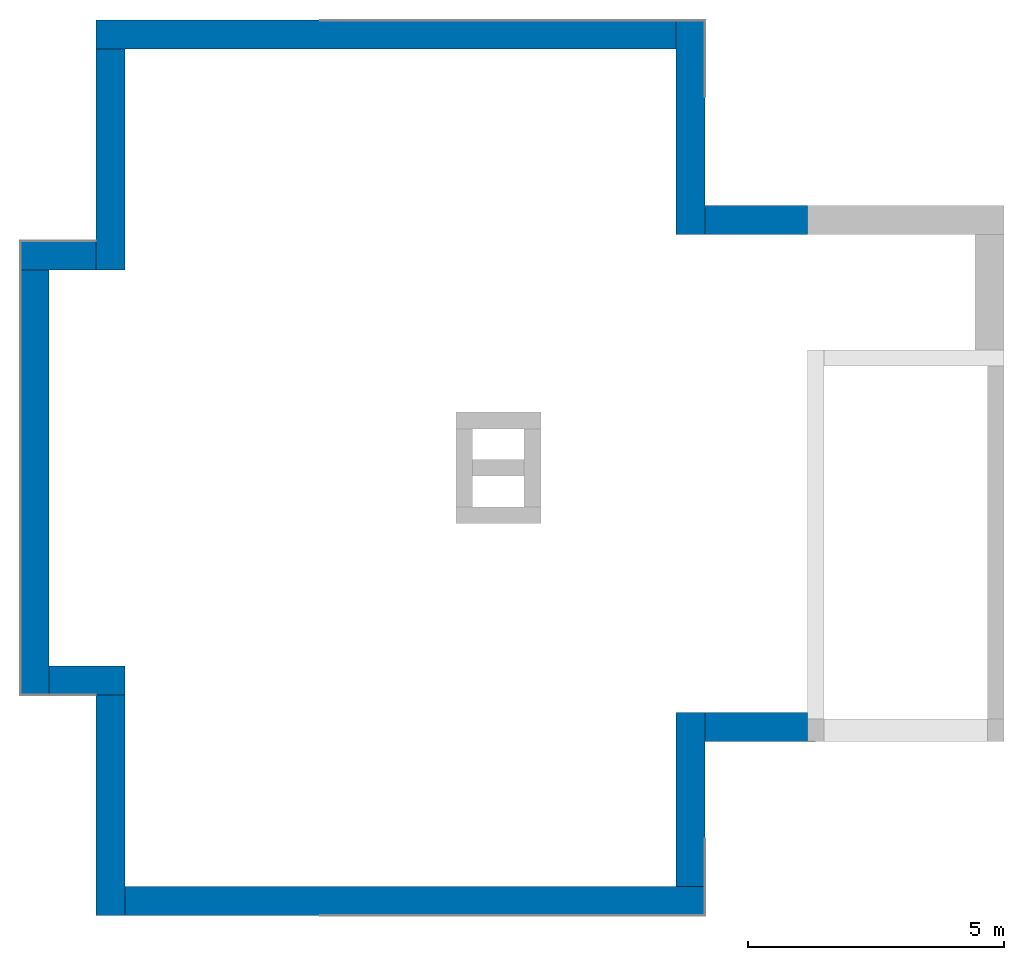
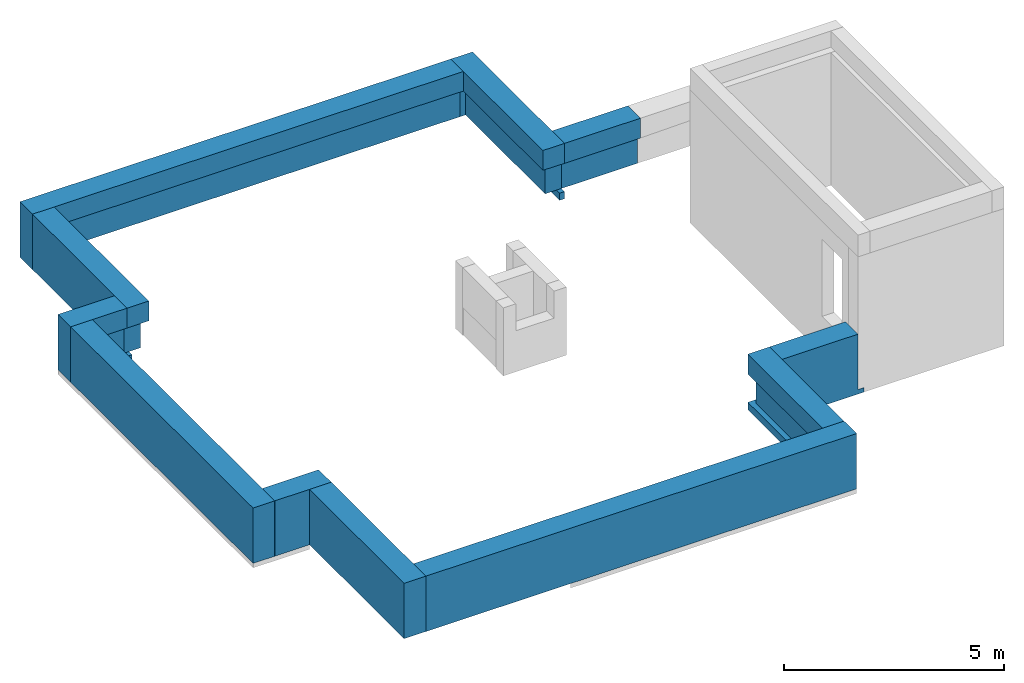
# One storey, part 2 of 2: 11 walls.
"""IFC2X3 building model written with IfcOpenShell, lengths in millimetres."""

from ifc_helpers import new_model, entity, si_unit, converted_unit, derived_unit, direction, frame, origin, place, context, subcontext, project, spatial, faceted_brep, material, material_list, layer, layer_set, type_object, element, save


model = new_model("IFC2X3")

# Units and contexts
model_context = context("Model", 3, precision=0.01, world=origin(), true_north=direction((6.12303176911189e-17, 1.0)))
body_context = subcontext(model_context, "Body", "Model", "MODEL_VIEW")
ifc_project = project(units=[si_unit("LENGTHUNIT", "METRE", prefix="MILLI"), si_unit("AREAUNIT", "SQUARE_METRE"), si_unit("VOLUMEUNIT", "CUBIC_METRE"), converted_unit("PLANEANGLEUNIT", "DEGREE", entity("IfcRatioMeasure", 0.0174532925199433), si_unit("PLANEANGLEUNIT", "RADIAN"), dimensions=[0, 0, 0, 0, 0, 0, 0]), si_unit("MASSUNIT", "GRAM", prefix="KILO"), derived_unit("MASSDENSITYUNIT", [(si_unit("MASSUNIT", "GRAM", prefix="KILO"), 1), (si_unit("LENGTHUNIT", "METRE"), -3)]), si_unit("TIMEUNIT", "SECOND"), si_unit("FREQUENCYUNIT", "HERTZ"), si_unit("THERMODYNAMICTEMPERATUREUNIT", "DEGREE_CELSIUS"), derived_unit("THERMALTRANSMITTANCEUNIT", [(si_unit("MASSUNIT", "GRAM", prefix="KILO"), 1), (si_unit("THERMODYNAMICTEMPERATUREUNIT", "KELVIN"), -1), (si_unit("TIMEUNIT", "SECOND"), -3)]), derived_unit("VOLUMETRICFLOWRATEUNIT", [(si_unit("LENGTHUNIT", "METRE"), 3), (si_unit("TIMEUNIT", "SECOND"), -1)]), si_unit("ELECTRICCURRENTUNIT", "AMPERE"), si_unit("ELECTRICVOLTAGEUNIT", "VOLT"), si_unit("POWERUNIT", "WATT"), si_unit("FORCEUNIT", "NEWTON", prefix="KILO"), si_unit("ILLUMINANCEUNIT", "LUX"), si_unit("LUMINOUSFLUXUNIT", "LUMEN"), si_unit("LUMINOUSINTENSITYUNIT", "CANDELA"), derived_unit("USERDEFINED", [(si_unit("MASSUNIT", "GRAM", prefix="KILO"), -1), (si_unit("LENGTHUNIT", "METRE"), -2), (si_unit("TIMEUNIT", "SECOND"), 3), (si_unit("LUMINOUSFLUXUNIT", "LUMEN"), 1)]), derived_unit("LINEARVELOCITYUNIT", [(si_unit("LENGTHUNIT", "METRE"), 1), (si_unit("TIMEUNIT", "SECOND"), -1)]), si_unit("PRESSUREUNIT", "PASCAL"), derived_unit("USERDEFINED", [(si_unit("LENGTHUNIT", "METRE"), -2), (si_unit("MASSUNIT", "GRAM", prefix="KILO"), 1), (si_unit("TIMEUNIT", "SECOND"), -2)])], contexts=[model_context])

# Site, building, storey
site_placement = place(None, origin())
site = spatial("IfcSite", under=ifc_project, at=site_placement, CompositionType="ELEMENT")
building_placement = place(site_placement, origin())
building = spatial("IfcBuilding", under=site, at=building_placement, CompositionType="ELEMENT")
storey_placement = place(building_placement, frame((0.0, 0.0, 16000.0)))
storey = spatial("IfcBuildingStorey", under=building, at=storey_placement, Name="04 Roof", CompositionType="ELEMENT", Elevation=16000.0)

# Walls
ifc_material_1 = material(Name="03")
ifc_material_2 = material(Name="06_ APP")
ifc_material_3 = material()
ifc_material_4 = material(Name="02_C40/55")
ifc_material_5 = material()
ifc_material_list = material_list([ifc_material_1, ifc_material_2, ifc_material_3, ifc_material_4, ifc_material_5, ifc_material_1])
ifc_layer_1 = layer(ifc_material_1, 10.0)
ifc_layer_2 = layer(ifc_material_2, 10.0)
ifc_layer_3 = layer(ifc_material_3, 120.0)
ifc_layer_4 = layer(ifc_material_4, 300.0)
ifc_layer_5 = layer(ifc_material_5, 120.0)
ifc_layer_6 = layer(ifc_material_1, 10.0)
ifc_layer_set = layer_set([ifc_layer_1, ifc_layer_2, ifc_layer_3, ifc_layer_4, ifc_layer_5, ifc_layer_6], Name="Basic Wall:00_beton fal+2x12 cm")
wall_type = type_object("IfcWallType", Name="Basic Wall:00_beton fal+2x12 cm", PredefinedType="STANDARD", material=ifc_layer_set)
wall_1_placement = place(storey_placement, frame((28658.4900708518, -64275.8241905964, -340.0), z_axis=(0.0, 0.0, 1.0), x_axis=(0.0, 1.0, 0.0)))
element("IfcWall", 1, at=wall_1_placement, inside=storey, type_object=wall_type, material=ifc_material_list, Name="Basic Wall:00_beton fal+2x12 cm", ObjectType="Basic Wall:00_beton fal+2x12 cm", context=body_context, shape_type="Brep", body=[
    faceted_brep([(0.0, -285.0, 0.0), (440.0, -285.0, 0.0), (560.0, -285.0, 0.0), (2254.58460545632, -285.0, 0.0), (2694.58460545633, -285.0, 0.0), (4184.5846054564, -285.0, 0.0), (4194.5846054564, -285.0, 0.0), (4194.5846054564, -285.0, 1540.0), (570.0, -285.0, 1540.0), (0.0, -285.0, 1540.0), (0.0, -285.0, 984.711630304925), (140.0, -285.0, 990.0), (140.0, -285.0, 200.0), (0.0, -285.0, 200.0), (0.0, 285.0, 1540.0), (3624.5846054564, 285.0, 1540.0), (4194.5846054564, 285.0, 1540.0), (4194.5846054564, 285.0, 0.0), (4064.58460545641, 285.0, 0.0), (4064.58460545641, 285.0, 200.0), (3764.5846054564, 285.0, 200.0), (3764.58460545639, 285.0, 990.0), (3709.42156197813, 285.0, 993.043478260867), (3624.5846054564, 285.0, 993.043478260867), (0.0, 285.0, 993.043478260867), (0.0, -155.0, 0.0), (2564.58460545641, -155.0, 0.0), (4064.58460545641, -155.0, 0.0), (4064.58460545641, -155.0, 200.0), (2564.58460545641, -155.0, 200.0), (140.0, -155.0, 200.0), (140.0, 145.0, 200.0), (3764.5846054564, 145.0, 200.0), (0.0, -155.0, 200.0), (3764.5846054564, 145.0, 990.0), (140.0, 145.0, 990.0), (0.0, 145.0, 990.0), (0.0, 53.2090117211984, 984.711630304925)], [[[0, 1, 2, 3, 4, 5, 6, 7, 8, 9, 10, 11, 12, 13]], [[14, 15, 16, 17, 18, 19, 20, 21, 22, 23, 24]], [[6, 5, 4, 3, 2, 1, 0, 25, 26, 27, 18, 17]], [[9, 8, 7, 16, 15, 14]], [[7, 6, 17, 16]], [[19, 28, 29, 30, 31, 32, 20]], [[28, 27, 26, 25, 33, 30, 29]], [[27, 28, 19, 18]], [[12, 30, 33, 13]], [[32, 34, 21, 20]], [[31, 35, 34, 32]], [[34, 22, 21]], [[34, 35, 36, 24, 23, 22]], [[9, 14, 24, 36, 37, 10]], [[35, 31, 30, 12, 11]], [[35, 37, 36]], [[37, 35, 11, 10]], [[25, 0, 13, 33]]]),
])
wall_2_placement = place(storey_placement, frame((28373.4900708518, -60366.23958514, -340.0), z_axis=(0.0, 0.0, 1.0), x_axis=(-1.0, 0.0, 0.0)))
element("IfcWall", 2, at=wall_2_placement, inside=storey, type_object=wall_type, Name="Basic Wall:00_beton fal+2x12 cm", ObjectType="Basic Wall:00_beton fal+2x12 cm", context=body_context, shape_type="Brep", body=[
    faceted_brep([(0.0, -285.0, 0.0), (6950.0, -285.0, 0.0), (7390.0, -285.0, 0.0), (11330.0, -285.0, 0.0), (11330.0, -285.0, 1540.0), (0.0, -285.0, 1540.0), (0.0, 285.0, 1540.0), (10760.0, 285.0, 1540.0), (11330.0, 285.0, 1540.0), (11330.0, 285.0, 0.0), (11200.0, 285.0, 0.0), (11200.0, 285.0, 200.0), (10900.0, 285.0, 200.0), (10900.0, 285.0, 990.0), (10760.0, 285.0, 993.043478260867), (10544.6896551724, 285.0, 997.724137931034), (215.310344827578, 285.0, 997.724137931032), (0.0, 285.0, 993.043478260867), (0.0, -155.0, 0.0), (7080.0, -155.0, 0.0), (11200.0, -155.0, 0.0), (11330.0, 155.0, 0.0), (0.0, 200.163043478277, 993.043478260871), (0.0, 145.0, 990.0), (0.0, 145.0, 200.0), (0.0, -155.0, 200.0), (11200.0, -155.0, 200.0), (7080.0, -155.0, 200.0), (10900.0, 145.0, 200.0), (10900.0, 145.0, 990.0)], [[[0, 1, 2, 3, 4, 5]], [[6, 7, 8, 9, 10, 11, 12, 13, 14, 15, 16, 17]], [[3, 2, 1, 0, 18, 19, 20, 10, 9, 21]], [[5, 4, 8, 7, 6]], [[0, 5, 6, 17, 22, 23, 24, 25, 18]], [[4, 3, 21, 9, 8]], [[11, 26, 27, 25, 24, 28, 12]], [[26, 20, 19, 18, 25, 27]], [[20, 26, 11, 10]], [[28, 29, 13, 12]], [[29, 28, 24, 23]], [[22, 16, 15, 29, 23]], [[29, 15, 14, 13]], [[16, 22, 17]]]),
])
wall_3_placement = place(storey_placement, frame((17328.4900708518, -60651.2395851399, -340.0), z_axis=(0.0, 0.0, 1.0), x_axis=(0.0, -1.0, 0.0)))
element("IfcWall", 3, at=wall_3_placement, inside=storey, type_object=wall_type, Name="Basic Wall:00_beton fal+2x12 cm", ObjectType="Basic Wall:00_beton fal+2x12 cm", context=body_context, shape_type="Brep", body=[
    faceted_brep([(0.0, -285.0, 0.0), (3740.0, -285.0, 0.0), (3750.0, -285.0, 0.0), (3870.0, -285.0, 0.0), (4310.0, -285.0, 0.0), (4310.0, -285.0, 200.0), (4170.0, -285.0, 200.0), (4170.0, -285.0, 990.0), (4310.0, -285.0, 985.831791605636), (4310.0, -285.0, 1540.0), (3740.0, -285.0, 1540.0), (0.0, -285.0, 1540.0), (0.0, 285.0, 1540.0), (4310.0, 285.0, 1540.0), (4310.0, 285.0, 985.831791605638), (4170.0, 285.0, 990.0), (4115.85144927535, 285.0, 993.043478260869), (0.0, 285.0, 993.043478260869), (0.0, -155.0, 0.0), (4310.0, -155.0, 0.0), (0.0, 145.0, 990.0), (0.0, 145.0, 200.0), (0.0, -155.0, 200.0), (4170.0, 145.0, 200.0), (4170.0, -155.0, 200.0), (4310.0, -155.0, 200.0), (4170.0, 145.0, 990.0)], [[[0, 1, 2, 3, 4, 5, 6, 7, 8, 9, 10, 11]], [[12, 13, 14, 15, 16, 17]], [[4, 3, 2, 1, 0, 18, 19]], [[11, 10, 9, 13, 12]], [[0, 11, 12, 17, 20, 21, 22, 18]], [[13, 9, 8, 14]], [[22, 21, 23, 24]], [[19, 18, 22, 24, 25]], [[24, 6, 5, 25]], [[23, 26, 7, 6, 24]], [[26, 23, 21, 20]], [[7, 26, 15, 14, 8]], [[26, 20, 17, 16]], [[26, 16, 15]], [[4, 19, 25, 5]]]),
])
wall_4_placement = place(storey_placement, frame((17043.4900708518, -64676.2395851399, -340.0), z_axis=(0.0, 0.0, 1.0), x_axis=(-1.0, 0.0, 0.0)))
element("IfcWall", 4, at=wall_4_placement, inside=storey, type_object=wall_type, Name="Basic Wall:00_beton fal+2x12 cm", ObjectType="Basic Wall:00_beton fal+2x12 cm", context=body_context, shape_type="Brep", body=[
    faceted_brep([(0.0, -285.0, 0.0), (7.50000000000542, -285.0, 0.0), (1485.0, -285.0, 0.0), (1485.0, -285.0, 1540.0), (0.0, -285.0, 1540.0), (0.0, 285.0, 1540.0), (915.0, 285.0, 1540.0), (1485.0, 285.0, 1540.0), (1485.0, 285.0, 0.0), (1370.0, 285.0, 0.0), (1370.0, 285.0, 200.0), (1055.0, 285.0, 200.0), (1055.0, 285.0, 990.0), (915.0, 285.0, 985.87678594252), (913.472258030741, 285.0, 985.831791605636), (0.0, 285.0, 985.831791605636), (0.0, -155.0, 0.0), (1370.0, -155.0, 0.0), (1485.0, -275.0, 0.0), (0.0, 145.0, 990.0), (0.0, 145.0, 200.0), (0.0, -155.0, 200.0), (1370.0, -155.0, 200.0), (1055.0, 145.0, 200.0), (1055.0, 145.0, 990.0)], [[[0, 1, 2, 3, 4]], [[5, 6, 7, 8, 9, 10, 11, 12, 13, 14, 15]], [[2, 1, 0, 16, 17, 9, 8, 18]], [[4, 3, 7, 6, 5]], [[0, 4, 5, 15, 19, 20, 21, 16]], [[3, 2, 18, 8, 7]], [[10, 22, 21, 20, 23, 11]], [[17, 22, 10, 9]], [[22, 17, 16, 21]], [[23, 24, 12, 11]], [[24, 23, 20, 19]], [[14, 24, 19, 15]], [[24, 14, 13, 12]]]),
])
wall_5_placement = place(storey_placement, frame((15843.4900708518, -64961.2395851399, -340.0), z_axis=(0.0, 0.0, 1.0), x_axis=(0.0, -1.0, 0.0)))
element("IfcWall", 5, at=wall_5_placement, inside=storey, type_object=wall_type, Name="Basic Wall:00_beton fal+2x12 cm", ObjectType="Basic Wall:00_beton fal+2x12 cm", context=body_context, shape_type="Brep", body=[
    faceted_brep([(0.0, -285.0, 0.0), (8310.0, -285.0, 0.0), (8310.0, -285.0, 1540.0), (0.0, -285.0, 1540.0), (0.0, 285.0, 1540.0), (7740.0, 285.0, 1540.0), (8310.0, 285.0, 1540.0), (8310.0, 285.0, 0.0), (8180.0, 285.0, 0.0), (8180.0, 285.0, 200.0), (7880.0, 285.0, 200.0), (7880.0, 285.0, 990.0), (7742.92060995737, 285.0, 985.87678594252), (7740.0, 285.0, 985.87678594252), (0.0, 285.0, 985.876785942522), (0.0, -170.0, 0.0), (8180.0, -170.0, 0.0), (8310.0, -275.0, 0.0), (0.0, 145.0, 990.0), (0.0, 145.0, 200.0), (0.0, -170.0, 200.0), (8180.0, -170.0, 200.0), (7880.0, 145.0, 200.0), (7880.0, 145.0, 990.0)], [[[0, 1, 2, 3]], [[4, 5, 6, 7, 8, 9, 10, 11, 12, 13, 14]], [[1, 0, 15, 16, 8, 7, 17]], [[3, 2, 6, 5, 4]], [[0, 3, 4, 14, 18, 19, 20, 15]], [[2, 1, 17, 7, 6]], [[21, 20, 19, 22, 10, 9]], [[21, 16, 15, 20]], [[16, 21, 9, 8]], [[22, 23, 11, 10]], [[23, 22, 19, 18]], [[23, 12, 11]], [[12, 23, 18, 14, 13]]]),
])
wall_6_placement = place(storey_placement, frame((16128.4900708518, -72986.2395851399, -340.0)))
element("IfcWall", 6, at=wall_6_placement, inside=storey, type_object=wall_type, Name="Basic Wall:00_beton fal+2x12 cm", ObjectType="Basic Wall:00_beton fal+2x12 cm", context=body_context, shape_type="Brep", body=[
    faceted_brep([(1485.0, -285.0, 1540.0), (915.0, -285.0, 1540.0), (0.0, -285.0, 1540.0), (0.0, -285.0, 0.0), (907.499999999974, -285.0, 0.0), (915.0, -285.0, 0.0), (1045.0, -285.0, 0.0), (1045.0, -285.0, 200.0), (1345.0, -285.0, 200.0), (1345.0, -285.0, 990.0), (1485.0, -285.0, 986.942266571631), (0.0, 285.0, 1540.0), (1485.0, 285.0, 1540.0), (1485.0, 285.0, 985.788936849899), (2.98283639798335, 285.0, 985.788936849895), (0.0, 285.0, 985.876785942522), (0.0, -155.0, 0.0), (1045.0, -155.0, 0.0), (0.0, 282.079390042605, 985.876785942522), (0.0, 145.0, 990.0), (0.0, 145.0, 200.0), (0.0, -155.0, 200.0), (1485.0, 90.3442028985371, 986.942266571629), (1485.0, 145.0, 990.0), (1045.0, -155.0, 200.0), (1345.0, 145.0, 200.0), (1345.0, 145.0, 990.0)], [[[0, 1, 2, 3, 4, 5, 6, 7, 8, 9, 10]], [[11, 12, 13, 14, 15]], [[3, 16, 17, 6, 5, 4]], [[2, 1, 0, 12, 11]], [[3, 2, 11, 15, 18, 19, 20, 21, 16]], [[12, 0, 10, 22, 23, 13]], [[24, 21, 20, 25, 8, 7]], [[21, 24, 17, 16]], [[24, 7, 6, 17]], [[25, 26, 9, 8]], [[26, 25, 20, 19]], [[26, 22, 10, 9]], [[18, 14, 13, 23, 26, 19]], [[14, 18, 15]], [[22, 26, 23]]]),
])
wall_7_placement = place(storey_placement, frame((17328.4900708518, -73271.2395851399, -340.0), z_axis=(0.0, 0.0, 1.0), x_axis=(0.0, -1.0, 0.0)))
element("IfcWall", 7, at=wall_7_placement, inside=storey, type_object=wall_type, Name="Basic Wall:00_beton fal+2x12 cm", ObjectType="Basic Wall:00_beton fal+2x12 cm", context=body_context, shape_type="Brep", body=[
    faceted_brep([(0.0, -285.0, 0.0), (3870.0, -285.0, 0.0), (4310.0, -285.0, 0.0), (4310.0, -285.0, 1540.0), (0.0, -285.0, 1540.0), (0.0, 285.0, 1540.0), (3740.0, 285.0, 1540.0), (4310.0, 285.0, 1540.0), (4310.0, 285.0, 0.0), (4180.0, 285.0, 0.0), (4180.0, 285.0, 200.0), (3880.0, 285.0, 200.0), (3880.0, 285.0, 990.0), (3824.83220479923, 285.0, 986.942266571633), (3740.0, 285.0, 986.942266571633), (0.0, 285.0, 986.942266571631), (0.0, -155.0, 0.0), (4180.0, -155.0, 0.0), (0.0, 145.0, 990.0), (0.0, 145.0, 200.0), (0.0, -155.0, 200.0), (4180.0, -155.0, 200.0), (3880.0, 145.0, 200.0), (3880.0, 145.0, 990.0)], [[[0, 1, 2, 3, 4]], [[5, 6, 7, 8, 9, 10, 11, 12, 13, 14, 15]], [[2, 1, 0, 16, 17, 9, 8]], [[4, 3, 7, 6, 5]], [[0, 4, 5, 15, 18, 19, 20, 16]], [[3, 2, 8, 7]], [[10, 21, 20, 19, 22, 11]], [[17, 21, 10, 9]], [[21, 17, 16, 20]], [[22, 23, 12, 11]], [[23, 22, 19, 18]], [[13, 23, 18, 15, 14]], [[23, 13, 12]]]),
])
wall_8_placement = place(storey_placement, frame((17613.4900708518, -77296.2395851399, -340.0)))
element("IfcWall", 8, at=wall_8_placement, inside=storey, type_object=wall_type, Name="Basic Wall:00_beton fal+2x12 cm", ObjectType="Basic Wall:00_beton fal+2x12 cm", context=body_context, shape_type="Brep", body=[
    faceted_brep([(0.0, -285.0, 0.0), (3370.0, -285.0, 0.0), (3810.0, -285.0, 0.0), (11330.0, -285.0, 0.0), (11330.0, -285.0, 1540.0), (0.0, -285.0, 1540.0), (0.0, 285.0, 1540.0), (10760.0, 285.0, 1540.0), (11330.0, 285.0, 1540.0), (11330.0, 285.0, 0.0), (11200.0, 285.0, 0.0), (11200.0, 285.0, 200.0), (10900.0, 285.0, 200.0), (10900.0, 285.0, 990.0), (10760.0, 285.0, 986.97064460809), (10541.3921113689, 285.0, 982.240351849957), (215.279741172788, 285.0, 982.240351849959), (0.0, 285.0, 986.942266571631), (0.0, -155.0, 0.0), (3680.0, -155.0, 0.0), (11200.0, -155.0, 0.0), (11330.0, -275.0, 0.0), (0.0, 200.167795200752, 986.942266571633), (0.0, 145.0, 990.0), (0.0, 145.0, 200.0), (0.0, -155.0, 200.0), (11200.0, -155.0, 200.0), (3680.0, -155.0, 200.0), (10900.0, 145.0, 200.0), (10900.0, 145.0, 990.0)], [[[0, 1, 2, 3, 4, 5]], [[6, 7, 8, 9, 10, 11, 12, 13, 14, 15, 16, 17]], [[3, 2, 1, 0, 18, 19, 20, 10, 9, 21]], [[5, 4, 8, 7, 6]], [[0, 5, 6, 17, 22, 23, 24, 25, 18]], [[4, 3, 21, 9, 8]], [[11, 26, 27, 25, 24, 28, 12]], [[18, 25, 27, 26, 20, 19]], [[20, 26, 11, 10]], [[28, 29, 13, 12]], [[29, 28, 24, 23]], [[16, 22, 17]], [[22, 16, 15, 29, 23]], [[29, 15, 14, 13]]]),
])
wall_9_placement = place(storey_placement, frame((28658.4900708518, -77011.2395851399, -340.0), z_axis=(0.0, 0.0, 1.0), x_axis=(0.0, 1.0, 0.0)))
element("IfcWall", 9, at=wall_9_placement, inside=storey, type_object=wall_type, Name="Basic Wall:00_beton fal+2x12 cm", ObjectType="Basic Wall:00_beton fal+2x12 cm", context=body_context, shape_type="Brep", body=[
    faceted_brep([(0.0, -285.0, 0.0), (3400.41539454362, -285.0, 0.0), (3400.41539454362, -285.0, 200.0), (3260.41539454362, -285.0, 200.0), (3260.4153945436, -285.0, 990.0), (3400.41539454362, -285.0, 985.265218503155), (3400.41539454362, -285.0, 1540.0), (2830.41539454362, -285.0, 1540.0), (0.0, -285.0, 1540.0), (3400.41539454362, 285.0, 0.0), (1060.0, 285.0, 0.0), (1060.0, 285.0, 200.0), (3400.41539454362, 285.0, 200.0), (0.0, -155.0, 0.0), (1060.0, -155.0, 0.0), (3400.41539454362, 285.0, 1540.0), (0.0, 285.0, 1540.0), (0.0, 285.0, 986.97064460809), (0.0, 145.0, 990.0), (0.0, 145.0, 200.0), (0.0, -155.0, 200.0), (3400.41539454362, 62.7184572421064, 985.265218503153), (3400.41539454362, 145.0, 990.0), (3400.41539454362, 285.0, 986.970644608088), (1060.0, -155.0, 200.0), (1060.0, 145.0, 200.0), (3260.41539454362, 145.0, 200.0), (3260.41539454362, 145.0, 990.0), (3270.41539454368, 145.0, 990.0)], [[[0, 1, 2, 3, 4, 5, 6, 7, 8]], [[9, 10, 11, 12]], [[1, 0, 13, 14, 10, 9]], [[8, 7, 6, 15, 16]], [[0, 8, 16, 17, 18, 19, 20, 13]], [[15, 6, 5, 21, 22, 23]], [[24, 20, 19, 25]], [[14, 24, 25, 11, 10]], [[24, 14, 13, 20]], [[25, 26, 3, 2, 12, 11]], [[26, 27, 4, 3]], [[27, 26, 25, 19, 18]], [[4, 27, 21, 5]], [[28, 27, 18, 17, 23, 22]], [[27, 28, 22, 21]], [[1, 9, 12, 2]], [[16, 15, 23, 17]]]),
])
wall_10_placement = place(storey_placement, frame((28943.4900708518, -73895.8241905963, -465.0)))
element("IfcWall", 10, at=wall_10_placement, inside=storey, type_object=wall_type, Name="Basic Wall:00_beton fal+2x12 cm", ObjectType="Basic Wall:00_beton fal+2x12 cm", context=body_context, shape_type="Brep", body=[
    faceted_brep([(0.0, -285.0, 0.0), (2160.0, -285.0, 0.0), (2160.0, -285.0, 125.0), (2000.0, -285.0, 125.0), (2000.0, -285.0, 1665.0), (0.0, -285.0, 1665.0), (0.0, 285.0, 1665.0), (2000.0, 285.0, 1665.0), (2000.0, 285.0, 1115.0), (1917.91698508166, 285.0, 1110.26521850316), (0.0, 285.0, 1110.26521850316), (0.0, -275.0, 0.0), (2160.0, -275.0, 0.0), (0.0, 145.0, 1115.0), (0.0, 145.0, 325.0), (0.0, -155.0, 325.0), (0.0, -155.0, 125.0), (0.0, -275.0, 125.0), (2160.0, -275.0, 125.0), (2000.0, -275.0, 125.0), (2000.0, -155.0, 125.0), (2000.0, -155.0, 325.0), (2000.0, 145.0, 325.0), (2000.0, 145.0, 1115.0)], [[[0, 1, 2, 3, 4, 5]], [[6, 7, 8, 9, 10]], [[1, 0, 11, 12]], [[5, 4, 7, 6]], [[0, 5, 6, 10, 13, 14, 15, 16, 17, 11]], [[2, 1, 12, 18]], [[3, 2, 18, 19]], [[7, 4, 3, 19, 20, 21, 22, 23, 8]], [[14, 13, 23, 22]], [[23, 13, 10, 9]], [[23, 9, 8]], [[15, 14, 22, 21]], [[16, 15, 21, 20]], [[19, 17, 16, 20]], [[17, 19, 18, 12, 11]]]),
])
wall_11_placement = place(storey_placement, frame((28943.4900708518, -63990.8241905964, -465.0)))
element("IfcWall", 11, at=wall_11_placement, inside=storey, type_object=wall_type, Name="Basic Wall:00_beton fal+2x12 cm", ObjectType="Basic Wall:00_beton fal+2x12 cm", context=body_context, shape_type="Brep", body=[
    faceted_brep([(2000.0, -285.0, 1665.0), (0.0, -285.0, 1665.0), (0.0, -285.0, 1109.71163030493), (1908.2090117212, -285.0, 1109.71163030493), (2000.0, -285.0, 1115.0), (2000.0, 285.0, 0.0), (0.0, 285.0, 0.0), (0.0, 285.0, 1665.0), (2000.0, 285.0, 1665.0), (2000.0, 285.0, 125.0), (2000.0, 275.0, 0.0), (0.0, 275.0, 0.0), (2000.0, -145.0, 1115.0), (2000.0, -145.0, 325.0), (2000.0, 155.0, 325.0), (2000.0, 155.0, 125.0), (2000.0, 275.0, 125.0), (0.0, -145.0, 325.0), (0.0, 155.0, 325.0), (0.0, 155.0, 125.0), (0.0, 275.0, 125.0), (0.0, -145.0, 1115.0)], [[[0, 1, 2, 3, 4]], [[5, 6, 7, 8, 9]], [[6, 5, 10, 11]], [[5, 9, 8, 0, 4, 12, 13, 14, 15, 16, 10]], [[1, 0, 8, 7]], [[17, 18, 14, 13]], [[18, 19, 15, 14]], [[1, 7, 6, 11, 20, 19, 18, 17, 21, 2]], [[17, 13, 12, 21]], [[20, 16, 15, 19]], [[16, 20, 11, 10]], [[21, 12, 3, 2]], [[3, 12, 4]]]),
])

save(model, "model.ifc")
